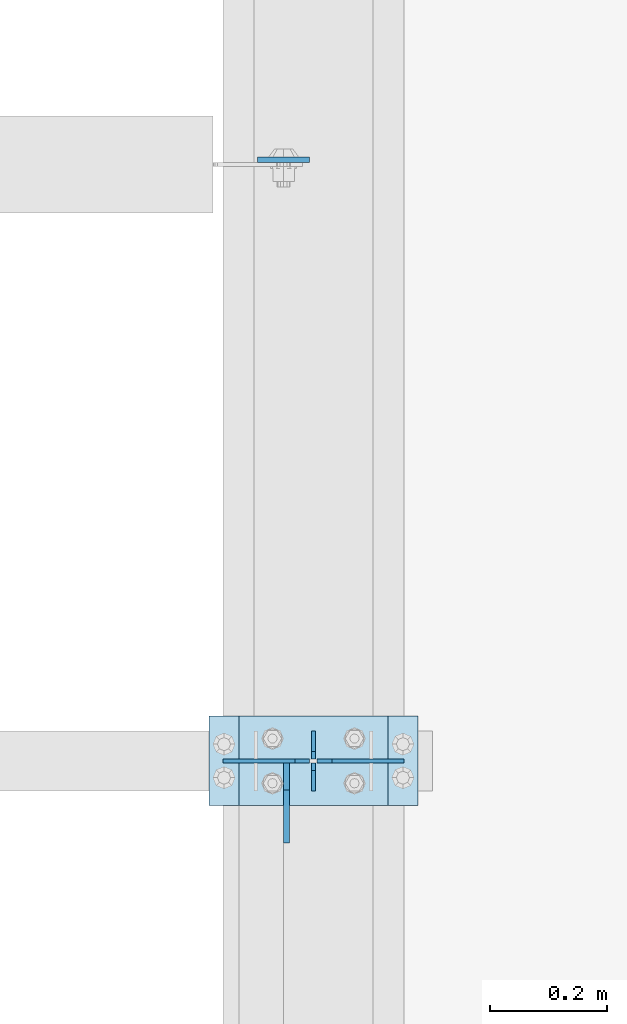
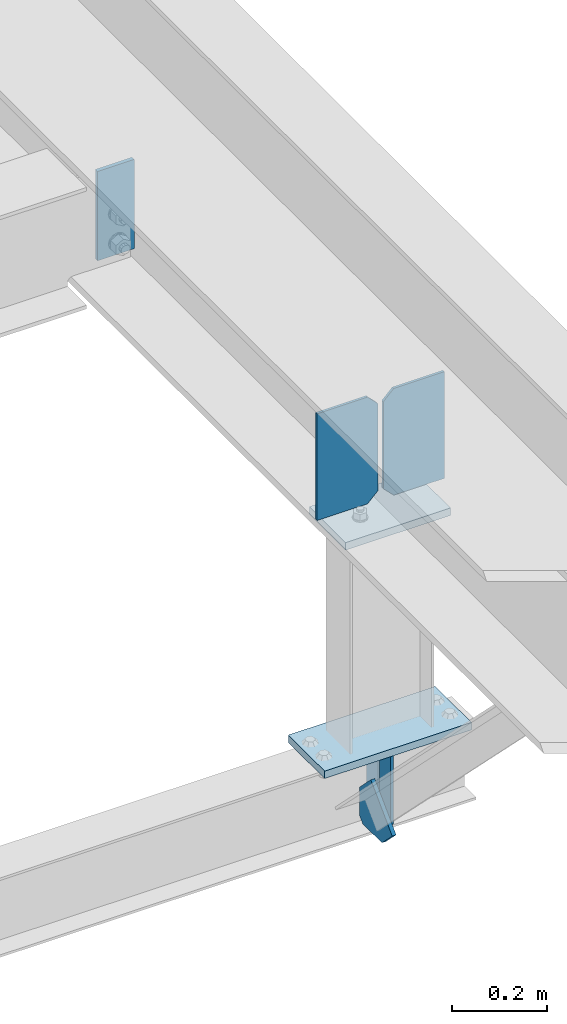
# One storey, part 3418 of 3843: 8 plates, 3 elements without a shape of their own.
"""IFC2X3 building model written with IfcOpenShell, lengths in millimetres."""

from ifc_helpers import new_model, si_unit, frame, origin_with_axes, place, context, subcontext, project, spatial, faceted_brep, material, type_object, element, aggregate, save


model = new_model("IFC2X3")

# Units and contexts
model_context = context("Model", 3, precision=1e-05, world=origin_with_axes())
body_context = subcontext(model_context, "Body", "Model", "MODEL_VIEW")
ifc_project = project(units=[si_unit("LENGTHUNIT", "METRE", prefix="MILLI"), si_unit("AREAUNIT", "SQUARE_METRE"), si_unit("VOLUMEUNIT", "CUBIC_METRE"), si_unit("MASSUNIT", "GRAM", prefix="KILO"), si_unit("TIMEUNIT", "SECOND"), si_unit("PLANEANGLEUNIT", "RADIAN"), si_unit("SOLIDANGLEUNIT", "STERADIAN"), si_unit("THERMODYNAMICTEMPERATUREUNIT", "DEGREE_CELSIUS"), si_unit("LUMINOUSINTENSITYUNIT", "LUMEN")], contexts=[model_context])

# Site, building, storey
site_placement = place(None, origin_with_axes())
site = spatial("IfcSite", under=ifc_project, at=site_placement, CompositionType="ELEMENT")
building_placement = place(site_placement, origin_with_axes())
building = spatial("IfcBuilding", under=site, at=building_placement, Name="Undefined", CompositionType="ELEMENT")
storey_placement = place(building_placement, origin_with_axes())
storey = spatial("IfcBuildingStorey", under=building, at=storey_placement, Name="Undefined", CompositionType="ELEMENT", Elevation=0.0)

# Assembly, plate
assembly_1_placement = place(storey_placement, origin_with_axes())
assembly_1 = element("IfcElementAssembly", 1, at=assembly_1_placement, inside=storey, Name="BEAM", AssemblyPlace="NOTDEFINED", PredefinedType="RIGID_FRAME")
ifc_material = material(Name="STEEL/A572-50")
plate_type_1 = type_object("IfcPlateType", PredefinedType="NOTDEFINED")
plate_1_placement = place(assembly_1_placement, frame((42056.05, 89123.8375000325, 42364.0250000247), z_axis=(-1.0, 0.0, 0.0), x_axis=(0.0, 0.0, -1.0)))
plate_1 = element("IfcPlate", 2, at=plate_1_placement, type_object=plate_type_1, material=ifc_material, Name="PLATE", context=body_context, shape_type="Brep", body=[
    faceted_brep([(0.0, -4.76249999999709, 0.0), (0.0, -4.76249999999709, 88.9000015258789), (0.0, 4.76249999999709, 88.9000015258789), (0.0, 4.76249999999709, 0.0), (228.600006102781, -4.7625000004191, 88.9000015257589), (228.600006102781, 4.76249999954598, 88.9000015257443), (228.600006103079, -4.7625000004482, 7.27595761418343e-12), (228.600006103079, 4.76249999954598, -7.27595761418343e-12)], [[[0, 1, 2, 3]], [[1, 4, 5, 2]], [[4, 6, 7, 5]], [[6, 0, 3, 7]], [[5, 7, 3, 2]], [[6, 4, 1, 0]]]),
])

# Assembly, plates
assembly_2_placement = place(storey_placement, origin_with_axes())
assembly_2 = element("IfcElementAssembly", 3, at=assembly_2_placement, inside=storey, Name="BEAM", AssemblyPlace="NOTDEFINED", PredefinedType="RIGID_FRAME")
plate_type_2 = type_object("IfcPlateType", PredefinedType="NOTDEFINED")
plate_2_placement = place(assembly_2_placement, frame((42062.4, 88049.1, 41495.6625), z_axis=(0.0, 0.0, -1.0), x_axis=(0.0, 1.0, 0.0)))
plate_2 = element("IfcPlate", 4, at=plate_2_placement, type_object=plate_type_2, material=ifc_material, Name="PLATE", context=body_context, shape_type="Brep", body=[
    faceted_brep([(0.0, -3.17499999999927, 0.0), (0.0, -3.17500000000291, 187.324999999997), (0.0, 3.17500000000291, 187.324999999997), (0.0, 3.17499999999927, 0.0), (34.9250001907349, -3.17500000000291, 187.324999999997), (34.9250001907349, 3.17500000000291, 187.324999999997), (47.625, -3.17500000000291, 174.625000190732), (47.625, 3.17500000000291, 174.625000190732), (47.625, -3.17499999999927, 12.6999998092651), (47.625, 3.17499999999927, 12.6999998092651), (34.9250001907349, -3.17499999999927, 0.0), (34.9250001907349, 3.17499999999927, 0.0)], [[[0, 1, 2, 3]], [[1, 4, 5, 2]], [[4, 6, 7, 5]], [[6, 8, 9, 7]], [[8, 10, 11, 9]], [[10, 0, 3, 11]], [[5, 7, 9, 11, 3, 2]], [[10, 8, 6, 4, 1, 0]]]),
])
plate_3_placement = place(assembly_2_placement, frame((42062.4, 88150.7, 41495.6625), z_axis=(0.0, 0.0, -1.0), x_axis=(0.0, -1.0, 0.0)))
plate_3 = element("IfcPlate", 5, at=plate_3_placement, type_object=plate_type_2, material=ifc_material, Name="PLATE", context=body_context, shape_type="Brep", body=[
    faceted_brep([(0.0, -3.17499999999927, 0.0), (0.0, -3.17500000000291, 187.324999999997), (0.0, 3.17500000000291, 187.324999999997), (0.0, 3.17499999999927, 0.0), (34.9250001907349, -3.17500000000291, 187.324999999997), (34.9250001907349, 3.17500000000291, 187.324999999997), (47.625, -3.17500000000291, 174.625000190732), (47.625, 3.17500000000291, 174.625000190732), (47.625, -3.17499999999927, 12.6999998092651), (47.625, 3.17499999999927, 12.6999998092651), (34.9250001907349, -3.17499999999927, 0.0), (34.9250001907349, 3.17499999999927, 0.0)], [[[0, 1, 2, 3]], [[1, 4, 5, 2]], [[4, 6, 7, 5]], [[6, 8, 9, 7]], [[8, 10, 11, 9]], [[10, 0, 3, 11]], [[5, 7, 9, 11, 3, 2]], [[10, 8, 6, 4, 1, 0]]]),
])

assembly_3_placement = place(storey_placement, origin_with_axes())
assembly_3 = element("IfcElementAssembly", 6, at=assembly_3_placement, inside=storey, Name="POST", AssemblyPlace="NOTDEFINED", PredefinedType="RIGID_FRAME")
plate_type_3 = type_object("IfcPlateType", PredefinedType="NOTDEFINED")
plate_4_placement = place(assembly_3_placement, frame((41935.3999970644, 88176.0969321233, 42079.8625004933), z_axis=(0.0, -0.999999948263239, 0.000321673000078448), x_axis=(1.0, 0.0, 0.0)))
plate_4 = element("IfcPlate", 7, at=plate_4_placement, type_object=plate_type_3, material=ifc_material, Name="PLATE", context=body_context, shape_type="Brep", body=[
    faceted_brep([(0.0, -9.52500000000146, 0.0), (0.0, -9.5249999999287, 152.40000000162), (0.0, 9.52500000002328, 152.40000000162), (0.0, 9.52500000000146, 0.0), (254.0, -9.5249999999287, 152.40000000162), (254.0, 9.52500000002328, 152.40000000162), (253.999999999998, -9.52500000000146, 0.0), (253.999999999998, 9.52500000000146, 0.0)], [[[0, 1, 2, 3]], [[1, 4, 5, 2]], [[4, 6, 7, 5]], [[6, 0, 3, 7]], [[5, 7, 3, 2]], [[6, 4, 1, 0]]]),
])
plate_5_placement = place(assembly_3_placement, frame((42240.2, 88023.7, 41513.125), z_axis=(-1.0, 0.0, 0.0), x_axis=(0.0, 1.0, 0.0)))
plate_5 = element("IfcPlate", 8, at=plate_5_placement, type_object=plate_type_3, material=ifc_material, Name="PLATE", context=body_context, shape_type="Brep", body=[
    faceted_brep([(0.0, -9.52500000000146, 0.0), (0.0, -9.52500000000146, 355.599999999999), (0.0, 9.52500000000146, 355.599999999999), (0.0, 9.52500000000146, 0.0), (152.399999999994, -9.52500000000146, 355.599999999999), (152.399999999994, 9.52500000000146, 355.599999999999), (152.400000000001, -9.52500000000146, 0.0), (152.400000000001, 9.52500000000146, 0.0)], [[[0, 1, 2, 3]], [[1, 4, 5, 2]], [[4, 6, 7, 5]], [[6, 0, 3, 7]], [[5, 7, 3, 2]], [[6, 4, 1, 0]]]),
])
aggregate(assembly_3, [plate_4, plate_5])

# Plate
plate_type_4 = type_object("IfcPlateType", PredefinedType="NOTDEFINED")
plate_6_placement = place(assembly_2_placement, frame((42016.3625, 88096.725, 41306.75), z_axis=(0.0, -1.0, 0.0), x_axis=(0.0, 0.0, 1.0)))
plate_6 = element("IfcPlate", 9, at=plate_6_placement, type_object=plate_type_4, material=ifc_material, Name="PLATE", context=body_context, shape_type="Brep", body=[
    faceted_brep([(0.0, -4.76250000000073, 12.6999998092651), (4.450703272596e-08, -4.76249999999709, 93.0710244828806), (4.450703272596e-08, 4.76249999999709, 93.0710244828806), (0.0, 4.76250000000073, 12.6999998092651), (43.3137807601452, -4.76249999999709, 136.384805065652), (43.3137807601452, 4.76249999999709, 136.384805065652), (133.209805202001, -4.76249999999709, 46.4887805392646), (133.209805202001, 4.76249999999709, 46.4887805392646), (86.7210245267561, -4.76249999999709, 0.0), (86.7210245267561, 4.76249999999709, 0.0), (12.6999998092651, -4.76250000000073, 0.0), (12.6999998092651, 4.76250000000073, 0.0)], [[[0, 1, 2, 3]], [[1, 4, 5, 2]], [[4, 6, 7, 5]], [[6, 8, 9, 7]], [[8, 10, 11, 9]], [[10, 0, 3, 11]], [[5, 7, 9, 11, 3, 2]], [[10, 8, 6, 4, 1, 0]]]),
])

aggregate(assembly_2, [plate_6, plate_2, plate_3])

plate_type_5 = type_object("IfcPlateType", PredefinedType="NOTDEFINED")
plate_7_placement = place(assembly_1_placement, frame((42216.3875, 88099.9944713393, 42384.3986005859), z_axis=(0.0, -0.000321673000085866, -0.999999948263239), x_axis=(-1.0, 0.0, 0.0)))
plate_7 = element("IfcPlate", 10, at=plate_7_placement, type_object=plate_type_5, material=ifc_material, Name="PLATE", context=body_context, shape_type="Brep", body=[
    faceted_brep([(0.0, -3.17499999999927, 0.0), (0.0, -3.17500000007567, 273.049999997937), (0.0, 3.17499999993743, 273.049999997937), (0.0, 3.17499999999927, 0.0), (122.237500389827, -3.17500000007567, 273.049999997937), (122.237500389827, 3.17499999993743, 273.049999997937), (147.637500008357, -3.17500000006476, 247.650000379464), (147.637500008357, 3.17499999994106, 247.650000379464), (147.637500008357, -3.17500000001382, 25.3999996184648), (147.637500008357, 3.17499999999927, 25.3999996184648), (122.237500389827, -3.17500000000291, 0.0), (122.237500389827, 3.17500000000291, -7.27595761418343e-12)], [[[0, 1, 2, 3]], [[1, 4, 5, 2]], [[4, 6, 7, 5]], [[6, 8, 9, 7]], [[8, 10, 11, 9]], [[10, 0, 3, 11]], [[5, 7, 9, 11, 3, 2]], [[10, 8, 6, 4, 1, 0]]]),
])

plate_8_placement = place(assembly_1_placement, frame((41908.4125, 88099.9944713393, 42384.3986005859), z_axis=(0.0, -0.000321673000085866, -0.999999948263239), x_axis=(1.0, 0.0, 0.0)))
plate_8 = element("IfcPlate", 11, at=plate_8_placement, type_object=plate_type_5, material=ifc_material, Name="PLATE", context=body_context, shape_type="Brep", body=[
    faceted_brep([(0.0, -3.17499999999927, 0.0), (0.0, -3.17500000007567, 273.049999997937), (0.0, 3.17499999993743, 273.049999997937), (0.0, 3.17499999999927, 0.0), (122.237500389827, -3.17500000007567, 273.049999997937), (122.237500389827, 3.17499999993743, 273.049999997937), (147.637500008357, -3.17500000006476, 247.650000379464), (147.637500008357, 3.17499999994106, 247.650000379464), (147.637500008357, -3.17500000001382, 25.3999996184648), (147.637500008357, 3.17499999999927, 25.3999996184648), (122.237500389827, -3.17500000000291, 0.0), (122.237500389827, 3.17500000000291, -7.27595761418343e-12)], [[[0, 1, 2, 3]], [[1, 4, 5, 2]], [[4, 6, 7, 5]], [[6, 8, 9, 7]], [[8, 10, 11, 9]], [[10, 0, 3, 11]], [[5, 7, 9, 11, 3, 2]], [[10, 8, 6, 4, 1, 0]]]),
])

aggregate(assembly_1, [plate_7, plate_8, plate_1])

save(model, "model.ifc")
